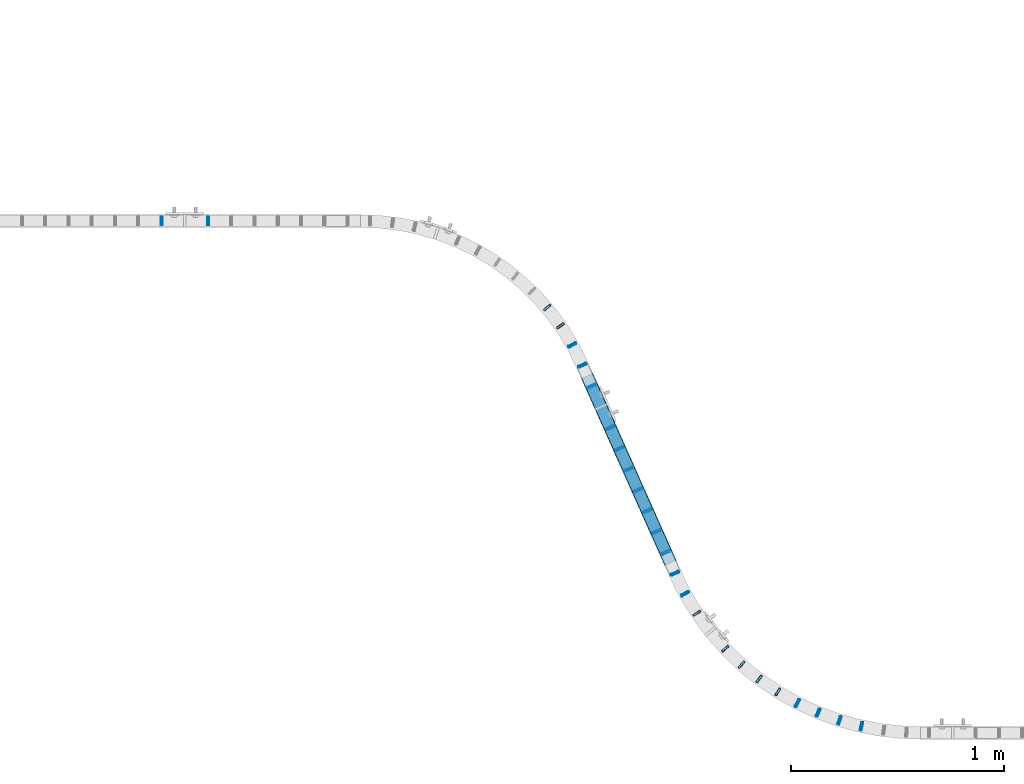
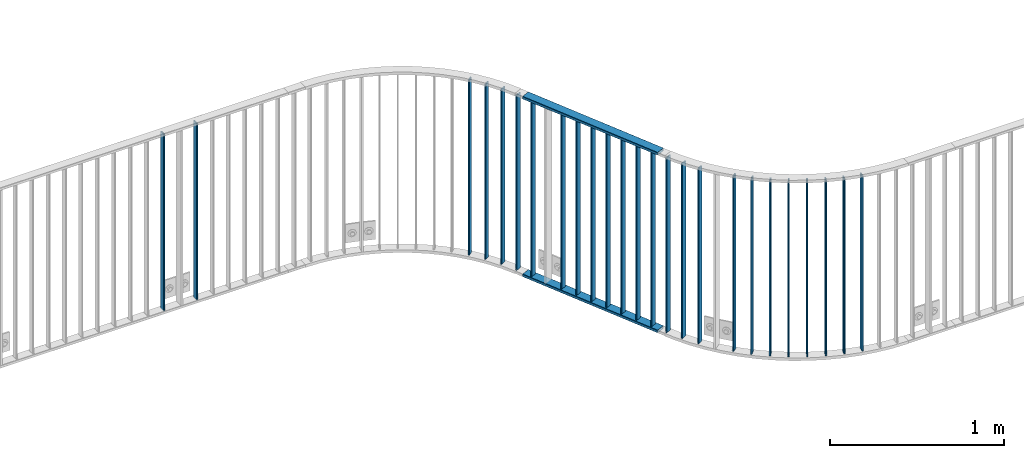
# One storey, part 16 of 156: 27 beams, 4 elements without a shape of their own.
"""IFC2X3 building model written with IfcOpenShell, lengths in millimetres."""

from ifc_helpers import new_model, si_unit, frame, origin_with_axes, origin_2d_with_axis, place, context, subcontext, project, spatial, hollow_rectangle, extrude, clip, halfspace, material, type_object, element, aggregate, save


model = new_model("IFC2X3")

# Units and contexts
model_context = context("Model", 3, precision=1e-05, world=origin_with_axes())
body_context = subcontext(model_context, "Body", "Model", "MODEL_VIEW")
ifc_project = project(units=[si_unit("LENGTHUNIT", "METRE", prefix="MILLI"), si_unit("AREAUNIT", "SQUARE_METRE"), si_unit("VOLUMEUNIT", "CUBIC_METRE"), si_unit("MASSUNIT", "GRAM", prefix="KILO"), si_unit("TIMEUNIT", "SECOND"), si_unit("PLANEANGLEUNIT", "RADIAN"), si_unit("SOLIDANGLEUNIT", "STERADIAN"), si_unit("THERMODYNAMICTEMPERATUREUNIT", "DEGREE_CELSIUS"), si_unit("LUMINOUSINTENSITYUNIT", "LUMEN")], contexts=[model_context])

# Site, building, storey
site_placement = place(None, origin_with_axes())
site = spatial("IfcSite", under=ifc_project, at=site_placement, CompositionType="ELEMENT")
building_placement = place(site_placement, origin_with_axes())
building = spatial("IfcBuilding", under=site, at=building_placement, Name="Undefined", CompositionType="ELEMENT")
storey_placement = place(building_placement, origin_with_axes())
storey = spatial("IfcBuildingStorey", under=building, at=storey_placement, Name="Undefined", CompositionType="ELEMENT", Elevation=0.0)

# Assembly, beams
assembly_1_placement = place(storey_placement, origin_with_axes())
assembly_1 = element("IfcElementAssembly", 1, at=assembly_1_placement, inside=storey, AssemblyPlace="NOTDEFINED", PredefinedType="RIGID_FRAME")
ifc_material = material(Name="STEEL/S235JR")
beam_type_1 = type_object("IfcBeamType", Name="K60/20/2", PredefinedType="NOTDEFINED")
beam_1_placement = place(assembly_1_placement, frame((26885.8109382689, 10154.6935671142, 2740.0), z_axis=(0.913309035992481, 0.407267239996644, 0.0), x_axis=(0.407267239996645, -0.913309035992481, 0.0)))
beam_1 = element("IfcBeam", 2, at=beam_1_placement, type_object=beam_type_1, material=ifc_material, ObjectType="K60/20/2", context=body_context, shape_type="SweptSolid", body=[
    extrude(hollow_rectangle(XDim=20.0, YDim=60.0, WallThickness=2.0, InnerFilletRadius=2.0, OuterFilletRadius=4.0, at=origin_2d_with_axis()), frame((961.211118565013, 0.0, 0.0), z_axis=(-1.0, 0.0, 0.0), x_axis=(0.0, -1.0, 0.0)), (0.0, 0.0, 1.0), 961.21),
])
beam_2_placement = place(assembly_1_placement, frame((26885.8109510396, 10154.6935384756, 3990.0), z_axis=(0.913308610110194, 0.407268195049142, 0.0), x_axis=(0.407268195049143, -0.913308610110193, 0.0)))
beam_2 = element("IfcBeam", 3, at=beam_2_placement, type_object=beam_type_1, material=ifc_material, ObjectType="K60/20/2", context=body_context, shape_type="SweptSolid", body=[
    extrude(hollow_rectangle(XDim=20.0, YDim=60.0, WallThickness=2.0, InnerFilletRadius=2.0, OuterFilletRadius=4.0, at=origin_2d_with_axis()), frame((961.165947383904, 0.0, 0.0), z_axis=(-1.0, 0.0, 0.0), x_axis=(0.0, -1.0, 0.0)), (0.0, 0.0, 1.0), 961.17),
])

# Assembly, beam
assembly_2_placement = place(storey_placement, origin_with_axes())
assembly_2 = element("IfcElementAssembly", 4, at=assembly_2_placement, inside=storey, AssemblyPlace="NOTDEFINED", PredefinedType="RIGID_FRAME")
beam_type_2 = type_object("IfcBeamType", Name="K40/10/1.5", PredefinedType="NOTDEFINED")
beam_3_placement = place(assembly_2_placement, frame((26864.1039227876, 10203.4804710711, 3980.00000000003), z_axis=(0.913608771055644, 0.406594409024764, 0.0), x_axis=(0.0, 0.0, -1.0)))
beam_3 = element("IfcBeam", 5, at=beam_3_placement, type_object=beam_type_2, material=ifc_material, ObjectType="K40/10/1.5", context=body_context, shape_type="SweptSolid", body=[
    extrude(hollow_rectangle(XDim=10.0, YDim=40.0, WallThickness=1.5, InnerFilletRadius=1.5, OuterFilletRadius=3.0, at=origin_2d_with_axis()), frame((1230.0, 0.0, 0.0), z_axis=(-1.0, 0.0, 0.0), x_axis=(0.0, -1.0, 0.0)), (0.0, 0.0, 1.0), 1230.0),
])

# Beam
beam_4_placement = place(assembly_1_placement, frame((26907.5939227876, 10105.9404710711, 3980.00000000003), z_axis=(0.913608771055644, 0.406594409024764, 0.0), x_axis=(0.0, 0.0, -1.0)))
beam_4 = element("IfcBeam", 6, at=beam_4_placement, type_object=beam_type_2, material=ifc_material, ObjectType="K40/10/1.5", context=body_context, shape_type="Clipping", body=[
    clip(clip(extrude(hollow_rectangle(XDim=10.0, YDim=40.0, WallThickness=1.5, InnerFilletRadius=1.5, OuterFilletRadius=3.0, at=origin_2d_with_axis()), frame((1237.00000000003, 0.0, 0.0), z_axis=(-1.0, 0.0, 0.0), x_axis=(0.0, -1.0, 0.0)), (0.0, 0.0, 1.0), 1244.0), halfspace(frame((1237.00000000003, -56.3749450640607, -3.21677039569113), z_axis=(1.0, 0.0, 0.0), x_axis=(0.0, -0.0578016017852366, -0.998328089773628)), False)), halfspace(frame((-6.99999999997408, 56.3749450528248, -3.21677038838243), z_axis=(-1.0, 0.0, 0.0), x_axis=(0.0, 0.0578016019523036, -0.998328089763955)), False)),
])

beam_5_placement = place(assembly_1_placement, frame((26994.5739227876, 9910.86047107108, 3980.00000000003), z_axis=(0.913608771055644, 0.406594409024764, 0.0), x_axis=(0.0, 0.0, -1.0)))
beam_5 = element("IfcBeam", 7, at=beam_5_placement, type_object=beam_type_2, material=ifc_material, ObjectType="K40/10/1.5", context=body_context, shape_type="Clipping", body=[
    clip(clip(extrude(hollow_rectangle(XDim=10.0, YDim=40.0, WallThickness=1.5, InnerFilletRadius=1.5, OuterFilletRadius=3.0, at=origin_2d_with_axis()), frame((1237.00000000003, 0.0, 0.0), z_axis=(-1.0, 0.0, 0.0), x_axis=(0.0, -1.0, 0.0)), (0.0, 0.0, 1.0), 1244.0), halfspace(frame((1237.00000000003, -56.3749450640607, -3.21677039569113), z_axis=(1.0, 0.0, 0.0), x_axis=(0.0, -0.0578016017852366, -0.998328089773628)), False)), halfspace(frame((-6.99999999997408, 56.3749450528248, -3.21677038838243), z_axis=(-1.0, 0.0, 0.0), x_axis=(0.0, 0.0578016019523036, -0.998328089763955)), False)),
])

beam_6_placement = place(assembly_1_placement, frame((27038.0639227876, 9813.32047107108, 3980.00000000003), z_axis=(0.913608771055644, 0.406594409024764, 0.0), x_axis=(0.0, 0.0, -1.0)))
beam_6 = element("IfcBeam", 8, at=beam_6_placement, type_object=beam_type_2, material=ifc_material, ObjectType="K40/10/1.5", context=body_context, shape_type="Clipping", body=[
    clip(clip(extrude(hollow_rectangle(XDim=10.0, YDim=40.0, WallThickness=1.5, InnerFilletRadius=1.5, OuterFilletRadius=3.0, at=origin_2d_with_axis()), frame((1237.00000000003, 0.0, 0.0), z_axis=(-1.0, 0.0, 0.0), x_axis=(0.0, -1.0, 0.0)), (0.0, 0.0, 1.0), 1244.0), halfspace(frame((1237.00000000003, -56.3749450640607, -3.21677039569113), z_axis=(1.0, 0.0, 0.0), x_axis=(0.0, -0.0578016017852366, -0.998328089773628)), False)), halfspace(frame((-6.99999999997408, 56.3749450528248, -3.21677038838243), z_axis=(-1.0, 0.0, 0.0), x_axis=(0.0, 0.0578016019523036, -0.998328089763955)), False)),
])

beam_7_placement = place(assembly_1_placement, frame((27081.5539227876, 9715.78047107108, 3980.00000000003), z_axis=(0.913608771055644, 0.406594409024764, 0.0), x_axis=(0.0, 0.0, -1.0)))
beam_7 = element("IfcBeam", 9, at=beam_7_placement, type_object=beam_type_2, material=ifc_material, ObjectType="K40/10/1.5", context=body_context, shape_type="Clipping", body=[
    clip(clip(extrude(hollow_rectangle(XDim=10.0, YDim=40.0, WallThickness=1.5, InnerFilletRadius=1.5, OuterFilletRadius=3.0, at=origin_2d_with_axis()), frame((1237.00000000003, 0.0, 0.0), z_axis=(-1.0, 0.0, 0.0), x_axis=(0.0, -1.0, 0.0)), (0.0, 0.0, 1.0), 1244.0), halfspace(frame((1237.00000000003, -56.3749450640607, -3.21677039569113), z_axis=(1.0, 0.0, 0.0), x_axis=(0.0, -0.0578016017852366, -0.998328089773628)), False)), halfspace(frame((-6.99999999997408, 56.3749450528248, -3.21677038838243), z_axis=(-1.0, 0.0, 0.0), x_axis=(0.0, 0.0578016019523036, -0.998328089763955)), False)),
])

beam_8_placement = place(assembly_1_placement, frame((27125.0439227876, 9618.24047107108, 3980.00000000003), z_axis=(0.913608771055644, 0.406594409024764, 0.0), x_axis=(0.0, 0.0, -1.0)))
beam_8 = element("IfcBeam", 10, at=beam_8_placement, type_object=beam_type_2, material=ifc_material, ObjectType="K40/10/1.5", context=body_context, shape_type="Clipping", body=[
    clip(clip(extrude(hollow_rectangle(XDim=10.0, YDim=40.0, WallThickness=1.5, InnerFilletRadius=1.5, OuterFilletRadius=3.0, at=origin_2d_with_axis()), frame((1237.00000000003, 0.0, 0.0), z_axis=(-1.0, 0.0, 0.0), x_axis=(0.0, -1.0, 0.0)), (0.0, 0.0, 1.0), 1244.0), halfspace(frame((1237.00000000003, -56.3749450640607, -3.21677039569113), z_axis=(1.0, 0.0, 0.0), x_axis=(0.0, -0.0578016017852366, -0.998328089773628)), False)), halfspace(frame((-6.99999999997408, 56.3749450528248, -3.21677038838243), z_axis=(-1.0, 0.0, 0.0), x_axis=(0.0, 0.0578016019523036, -0.998328089763955)), False)),
])

beam_9_placement = place(assembly_1_placement, frame((27168.5339227876, 9520.70047107108, 3980.00000000003), z_axis=(0.913608771055644, 0.406594409024764, 0.0), x_axis=(0.0, 0.0, -1.0)))
beam_9 = element("IfcBeam", 11, at=beam_9_placement, type_object=beam_type_2, material=ifc_material, ObjectType="K40/10/1.5", context=body_context, shape_type="Clipping", body=[
    clip(clip(extrude(hollow_rectangle(XDim=10.0, YDim=40.0, WallThickness=1.5, InnerFilletRadius=1.5, OuterFilletRadius=3.0, at=origin_2d_with_axis()), frame((1237.00000000003, 0.0, 0.0), z_axis=(-1.0, 0.0, 0.0), x_axis=(0.0, -1.0, 0.0)), (0.0, 0.0, 1.0), 1244.0), halfspace(frame((1237.00000000003, -56.3749450640607, -3.21677039569113), z_axis=(1.0, 0.0, 0.0), x_axis=(0.0, -0.0578016017852366, -0.998328089773628)), False)), halfspace(frame((-6.99999999997408, 56.3749450528248, -3.21677038838243), z_axis=(-1.0, 0.0, 0.0), x_axis=(0.0, 0.0578016019523036, -0.998328089763955)), False)),
])

beam_10_placement = place(assembly_1_placement, frame((27212.0239227876, 9423.16047107108, 3980.00000000003), z_axis=(0.913608771055644, 0.406594409024764, 0.0), x_axis=(0.0, 0.0, -1.0)))
beam_10 = element("IfcBeam", 12, at=beam_10_placement, type_object=beam_type_2, material=ifc_material, ObjectType="K40/10/1.5", context=body_context, shape_type="Clipping", body=[
    clip(clip(extrude(hollow_rectangle(XDim=10.0, YDim=40.0, WallThickness=1.5, InnerFilletRadius=1.5, OuterFilletRadius=3.0, at=origin_2d_with_axis()), frame((1237.00000000003, 0.0, 0.0), z_axis=(-1.0, 0.0, 0.0), x_axis=(0.0, -1.0, 0.0)), (0.0, 0.0, 1.0), 1244.0), halfspace(frame((1237.00000000003, -56.3749450640607, -3.21677039569113), z_axis=(1.0, 0.0, 0.0), x_axis=(0.0, -0.0578016017852366, -0.998328089773628)), False)), halfspace(frame((-6.99999999997408, 56.3749450528248, -3.21677038838243), z_axis=(-1.0, 0.0, 0.0), x_axis=(0.0, 0.0578016019523036, -0.998328089763955)), False)),
])

beam_11_placement = place(assembly_1_placement, frame((27255.5139227876, 9325.62047107108, 3980.00000000003), z_axis=(0.913608771055644, 0.406594409024764, 0.0), x_axis=(0.0, 0.0, -1.0)))
beam_11 = element("IfcBeam", 13, at=beam_11_placement, type_object=beam_type_2, material=ifc_material, ObjectType="K40/10/1.5", context=body_context, shape_type="Clipping", body=[
    clip(clip(extrude(hollow_rectangle(XDim=10.0, YDim=40.0, WallThickness=1.5, InnerFilletRadius=1.5, OuterFilletRadius=3.0, at=origin_2d_with_axis()), frame((1237.00000000003, 0.0, 0.0), z_axis=(-1.0, 0.0, 0.0), x_axis=(0.0, -1.0, 0.0)), (0.0, 0.0, 1.0), 1244.0), halfspace(frame((1237.00000000003, -56.3749450640607, -3.21677039569113), z_axis=(1.0, 0.0, 0.0), x_axis=(0.0, -0.0578016017852366, -0.998328089773628)), False)), halfspace(frame((-6.99999999997408, 56.3749450528248, -3.21677038838243), z_axis=(-1.0, 0.0, 0.0), x_axis=(0.0, 0.0578016019523036, -0.998328089763955)), False)),
])

aggregate(assembly_1, [beam_1, beam_2, beam_4, beam_5, beam_6, beam_7, beam_8, beam_9, beam_10, beam_11])

beam_12_placement = place(assembly_2_placement, frame((26817.1374499522, 10299.4665431202, 3980.00000000003), z_axis=(0.871567849067832, 0.490274907038157, 0.0), x_axis=(0.0, 0.0, -1.0)))
beam_12 = element("IfcBeam", 14, at=beam_12_placement, type_object=beam_type_2, material=ifc_material, ObjectType="K40/10/1.5", context=body_context, shape_type="SweptSolid", body=[
    extrude(hollow_rectangle(XDim=10.0, YDim=40.0, WallThickness=1.5, InnerFilletRadius=1.5, OuterFilletRadius=3.0, at=origin_2d_with_axis()), frame((1230.0, 0.0, 0.0), z_axis=(-1.0, 0.0, 0.0), x_axis=(0.0, -1.0, 0.0)), (0.0, 0.0, 1.0), 1230.0),
])

beam_13_placement = place(assembly_2_placement, frame((26761.2061114712, 10388.9452390588, 3980.00000000003), z_axis=(0.822554652220387, 0.568686068152366, 0.0), x_axis=(0.0, 0.0, -1.0)))
beam_13 = element("IfcBeam", 15, at=beam_13_placement, type_object=beam_type_2, material=ifc_material, ObjectType="K40/10/1.5", context=body_context, shape_type="SweptSolid", body=[
    extrude(hollow_rectangle(XDim=10.0, YDim=40.0, WallThickness=1.5, InnerFilletRadius=1.5, OuterFilletRadius=3.0, at=origin_2d_with_axis()), frame((1230.0, 0.0, 0.0), z_axis=(-1.0, 0.0, 0.0), x_axis=(0.0, -1.0, 0.0)), (0.0, 0.0, 1.0), 1230.0),
])

beam_14_placement = place(assembly_2_placement, frame((26699.0186966354, 10474.354975974, 3980.00000000003), z_axis=(0.766508116787897, 0.642234619822283, 0.0), x_axis=(0.0, 0.0, -1.0)))
beam_14 = element("IfcBeam", 16, at=beam_14_placement, type_object=beam_type_2, material=ifc_material, ObjectType="K40/10/1.5", context=body_context, shape_type="SweptSolid", body=[
    extrude(hollow_rectangle(XDim=10.0, YDim=40.0, WallThickness=1.5, InnerFilletRadius=1.5, OuterFilletRadius=3.0, at=origin_2d_with_axis()), frame((1230.0, 0.0, 0.0), z_axis=(-1.0, 0.0, 0.0), x_axis=(0.0, -1.0, 0.0)), (0.0, 0.0, 1.0), 1230.0),
])

aggregate(assembly_2, [beam_3, beam_12, beam_13, beam_14])

# Assembly, beam
assembly_3_placement = place(storey_placement, origin_with_axes())
assembly_3 = element("IfcElementAssembly", 17, at=assembly_3_placement, inside=storey, AssemblyPlace="NOTDEFINED", PredefinedType="RIGID_FRAME")
beam_15_placement = place(assembly_3_placement, frame((27298.2639227876, 9227.75047107107, 3980.00000000003), z_axis=(0.913608771055644, 0.406594409024764, 0.0), x_axis=(0.0, 0.0, -1.0)))
beam_15 = element("IfcBeam", 18, at=beam_15_placement, type_object=beam_type_2, material=ifc_material, ObjectType="K40/10/1.5", context=body_context, shape_type="SweptSolid", body=[
    extrude(hollow_rectangle(XDim=10.0, YDim=40.0, WallThickness=1.5, InnerFilletRadius=1.5, OuterFilletRadius=3.0, at=origin_2d_with_axis()), frame((1230.0, 0.0, 0.0), z_axis=(-1.0, 0.0, 0.0), x_axis=(0.0, -1.0, 0.0)), (0.0, 0.0, 1.0), 1230.0),
])

# Assembly, beams
assembly_4_placement = place(storey_placement, origin_with_axes())
assembly_4 = element("IfcElementAssembly", 19, at=assembly_4_placement, inside=storey, AssemblyPlace="NOTDEFINED", PredefinedType="RIGID_FRAME")
beam_16_placement = place(assembly_4_placement, frame((25109.089999999, 10879.9998088346, 3980.00000000003), z_axis=(0.0, 1.0, 0.0), x_axis=(0.0, 0.0, -1.0)))
beam_16 = element("IfcBeam", 20, at=beam_16_placement, type_object=beam_type_2, material=ifc_material, ObjectType="K40/10/1.5", context=body_context, shape_type="Clipping", body=[
    clip(clip(extrude(hollow_rectangle(XDim=10.0, YDim=40.0, WallThickness=1.5, InnerFilletRadius=1.5, OuterFilletRadius=3.0, at=origin_2d_with_axis()), frame((1237.00000000003, 0.0, 0.0), z_axis=(-1.0, 0.0, 0.0), x_axis=(0.0, -1.0, 0.0)), (0.0, 0.0, 1.0), 1244.0), halfspace(frame((1237.00000000003, 4.34248751949781, 47.3810900558092), z_axis=(1.0, 0.0, 0.0), x_axis=(0.0, -0.768354814194188, -0.640024124158313)), False)), halfspace(frame((-6.99999999997453, -4.34248751950508, 47.3810900558092), z_axis=(-1.0, 0.0, 0.0), x_axis=(0.0, 0.763991285051099, -0.645226562043109)), False)),
])
beam_17_placement = place(assembly_4_placement, frame((24890.899999999, 10879.9998088346, 3980.00000000003), z_axis=(0.0, 1.0, 0.0), x_axis=(0.0, 0.0, -1.0)))
beam_17 = element("IfcBeam", 21, at=beam_17_placement, type_object=beam_type_2, material=ifc_material, ObjectType="K40/10/1.5", context=body_context, shape_type="Clipping", body=[
    clip(clip(extrude(hollow_rectangle(XDim=10.0, YDim=40.0, WallThickness=1.5, InnerFilletRadius=1.5, OuterFilletRadius=3.0, at=origin_2d_with_axis()), frame((1237.00000000003, 0.0, 0.0), z_axis=(-1.0, 0.0, 0.0), x_axis=(0.0, -1.0, 0.0)), (0.0, 0.0, 1.0), 1244.0), halfspace(frame((1237.00000000003, 4.34248751949781, 47.3810900558092), z_axis=(1.0, 0.0, 0.0), x_axis=(0.0, -0.768354814194188, -0.640024124158313)), False)), halfspace(frame((-6.99999999997453, -4.34248751950508, 47.3810900558092), z_axis=(-1.0, 0.0, 0.0), x_axis=(0.0, 0.766598961668776, -0.642126180721792)), False)),
])
aggregate(assembly_4, [beam_16, beam_17])

# Beam
beam_18_placement = place(assembly_3_placement, frame((28173.2564637327, 8510.64216129181, 3980.00000000003), z_axis=(0.226215405979263, 0.974077301910704, 0.0), x_axis=(0.0, 0.0, -1.0)))
beam_18 = element("IfcBeam", 22, at=beam_18_placement, type_object=beam_type_2, material=ifc_material, ObjectType="K40/10/1.5", context=body_context, shape_type="SweptSolid", body=[
    extrude(hollow_rectangle(XDim=10.0, YDim=40.0, WallThickness=1.5, InnerFilletRadius=1.5, OuterFilletRadius=3.0, at=origin_2d_with_axis()), frame((1230.0, 0.0, 0.0), z_axis=(-1.0, 0.0, 0.0), x_axis=(0.0, -1.0, 0.0)), (0.0, 0.0, 1.0), 1230.0),
])

beam_19_placement = place(assembly_3_placement, frame((28070.3054773515, 8538.39456971824, 3980.00000000003), z_axis=(0.307761151072275, 0.951463648223446, 0.0), x_axis=(0.0, 0.0, -1.0)))
beam_19 = element("IfcBeam", 23, at=beam_19_placement, type_object=beam_type_2, material=ifc_material, ObjectType="K40/10/1.5", context=body_context, shape_type="SweptSolid", body=[
    extrude(hollow_rectangle(XDim=10.0, YDim=40.0, WallThickness=1.5, InnerFilletRadius=1.5, OuterFilletRadius=3.0, at=origin_2d_with_axis()), frame((1230.0, 0.0, 0.0), z_axis=(-1.0, 0.0, 0.0), x_axis=(0.0, -1.0, 0.0)), (0.0, 0.0, 1.0), 1230.0),
])

beam_20_placement = place(assembly_3_placement, frame((27970.069505795, 8574.75184927081, 3980.00000000003), z_axis=(0.387102991042564, 0.922036482101387, 0.0), x_axis=(0.0, 0.0, -1.0)))
beam_20 = element("IfcBeam", 24, at=beam_20_placement, type_object=beam_type_2, material=ifc_material, ObjectType="K40/10/1.5", context=body_context, shape_type="SweptSolid", body=[
    extrude(hollow_rectangle(XDim=10.0, YDim=40.0, WallThickness=1.5, InnerFilletRadius=1.5, OuterFilletRadius=3.0, at=origin_2d_with_axis()), frame((1230.0, 0.0, 0.0), z_axis=(-1.0, 0.0, 0.0), x_axis=(0.0, -1.0, 0.0)), (0.0, 0.0, 1.0), 1230.0),
])

beam_21_placement = place(assembly_3_placement, frame((27873.2663474501, 8619.45364235329, 3980.00000000003), z_axis=(0.463672753746687, 0.886006533515958, 0.0), x_axis=(0.0, 0.0, -1.0)))
beam_21 = element("IfcBeam", 25, at=beam_21_placement, type_object=beam_type_2, material=ifc_material, ObjectType="K40/10/1.5", context=body_context, shape_type="SweptSolid", body=[
    extrude(hollow_rectangle(XDim=10.0, YDim=40.0, WallThickness=1.5, InnerFilletRadius=1.5, OuterFilletRadius=3.0, at=origin_2d_with_axis()), frame((1230.0, 0.0, 0.0), z_axis=(-1.0, 0.0, 0.0), x_axis=(0.0, -1.0, 0.0)), (0.0, 0.0, 1.0), 1230.0),
])

beam_22_placement = place(assembly_3_placement, frame((27780.5892180339, 8672.17983559254, 3980.00000000003), z_axis=(0.53692211610272, 0.843631816161397, 0.0), x_axis=(0.0, 0.0, -1.0)))
beam_22 = element("IfcBeam", 26, at=beam_22_placement, type_object=beam_type_2, material=ifc_material, ObjectType="K40/10/1.5", context=body_context, shape_type="SweptSolid", body=[
    extrude(hollow_rectangle(XDim=10.0, YDim=40.0, WallThickness=1.5, InnerFilletRadius=1.5, OuterFilletRadius=3.0, at=origin_2d_with_axis()), frame((1230.0, 0.0, 0.0), z_axis=(-1.0, 0.0, 0.0), x_axis=(0.0, -1.0, 0.0)), (0.0, 0.0, 1.0), 1230.0),
])

beam_23_placement = place(assembly_3_placement, frame((27692.7017864165, 8732.5528521979, 3980.00000000003), z_axis=(0.606326533063551, 0.795215779083347, 0.0), x_axis=(0.0, 0.0, -1.0)))
beam_23 = element("IfcBeam", 27, at=beam_23_placement, type_object=beam_type_2, material=ifc_material, ObjectType="K40/10/1.5", context=body_context, shape_type="SweptSolid", body=[
    extrude(hollow_rectangle(XDim=10.0, YDim=40.0, WallThickness=1.5, InnerFilletRadius=1.5, OuterFilletRadius=3.0, at=origin_2d_with_axis()), frame((1230.0, 0.0, 0.0), z_axis=(-1.0, 0.0, 0.0), x_axis=(0.0, -1.0, 0.0)), (0.0, 0.0, 1.0), 1230.0),
])

beam_24_placement = place(assembly_3_placement, frame((27610.2334220314, 8800.14035582089, 3980.00000000003), z_axis=(0.671388993696032, 0.741105133664468, 0.0), x_axis=(0.0, 0.0, -1.0)))
beam_24 = element("IfcBeam", 28, at=beam_24_placement, type_object=beam_type_2, material=ifc_material, ObjectType="K40/10/1.5", context=body_context, shape_type="SweptSolid", body=[
    extrude(hollow_rectangle(XDim=10.0, YDim=40.0, WallThickness=1.5, InnerFilletRadius=1.5, OuterFilletRadius=3.0, at=origin_2d_with_axis()), frame((1230.0, 0.0, 0.0), z_axis=(-1.0, 0.0, 0.0), x_axis=(0.0, -1.0, 0.0)), (0.0, 0.0, 1.0), 1230.0),
])

beam_25_placement = place(assembly_3_placement, frame((27533.7746879071, 8874.45834655293, 3980.00000000003), z_axis=(0.731643580023374, 0.681687371021777, 0.0), x_axis=(0.0, 0.0, -1.0)))
beam_25 = element("IfcBeam", 29, at=beam_25_placement, type_object=beam_type_2, material=ifc_material, ObjectType="K40/10/1.5", context=body_context, shape_type="SweptSolid", body=[
    extrude(hollow_rectangle(XDim=10.0, YDim=40.0, WallThickness=1.5, InnerFilletRadius=1.5, OuterFilletRadius=3.0, at=origin_2d_with_axis()), frame((1230.0, 0.0, 0.0), z_axis=(-1.0, 0.0, 0.0), x_axis=(0.0, -1.0, 0.0)), (0.0, 0.0, 1.0), 1230.0),
])

beam_26_placement = place(assembly_3_placement, frame((27401.0292642749, 9041.11261284535, 3980.00000000003), z_axis=(0.836040697386645, 0.548667433253744, 0.0), x_axis=(0.0, 0.0, -1.0)))
beam_26 = element("IfcBeam", 30, at=beam_26_placement, type_object=beam_type_2, material=ifc_material, ObjectType="K40/10/1.5", context=body_context, shape_type="SweptSolid", body=[
    extrude(hollow_rectangle(XDim=10.0, YDim=40.0, WallThickness=1.5, InnerFilletRadius=1.5, OuterFilletRadius=3.0, at=origin_2d_with_axis()), frame((1230.0, 0.0, 0.0), z_axis=(-1.0, 0.0, 0.0), x_axis=(0.0, -1.0, 0.0)), (0.0, 0.0, 1.0), 1230.0),
])

beam_27_placement = place(assembly_3_placement, frame((27345.6931761277, 9132.25546291542, 3980.00000000003), z_axis=(0.879435631113389, 0.476017826061374, 0.0), x_axis=(0.0, 0.0, -1.0)))
beam_27 = element("IfcBeam", 31, at=beam_27_placement, type_object=beam_type_2, material=ifc_material, ObjectType="K40/10/1.5", context=body_context, shape_type="SweptSolid", body=[
    extrude(hollow_rectangle(XDim=10.0, YDim=40.0, WallThickness=1.5, InnerFilletRadius=1.5, OuterFilletRadius=3.0, at=origin_2d_with_axis()), frame((1230.0, 0.0, 0.0), z_axis=(-1.0, 0.0, 0.0), x_axis=(0.0, -1.0, 0.0)), (0.0, 0.0, 1.0), 1230.0),
])

aggregate(assembly_3, [beam_15, beam_18, beam_19, beam_20, beam_21, beam_22, beam_23, beam_24, beam_25, beam_26, beam_27])

save(model, "model.ifc")
